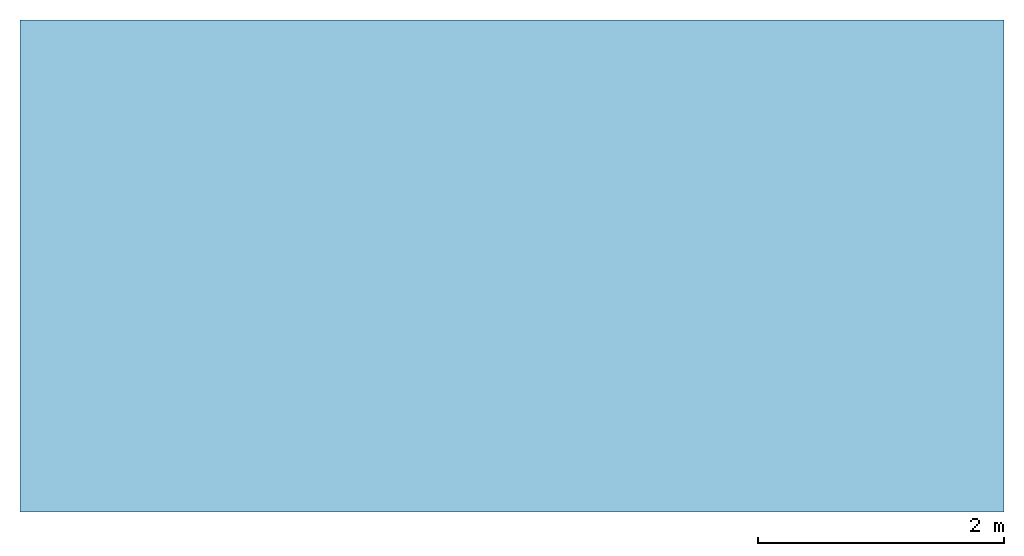
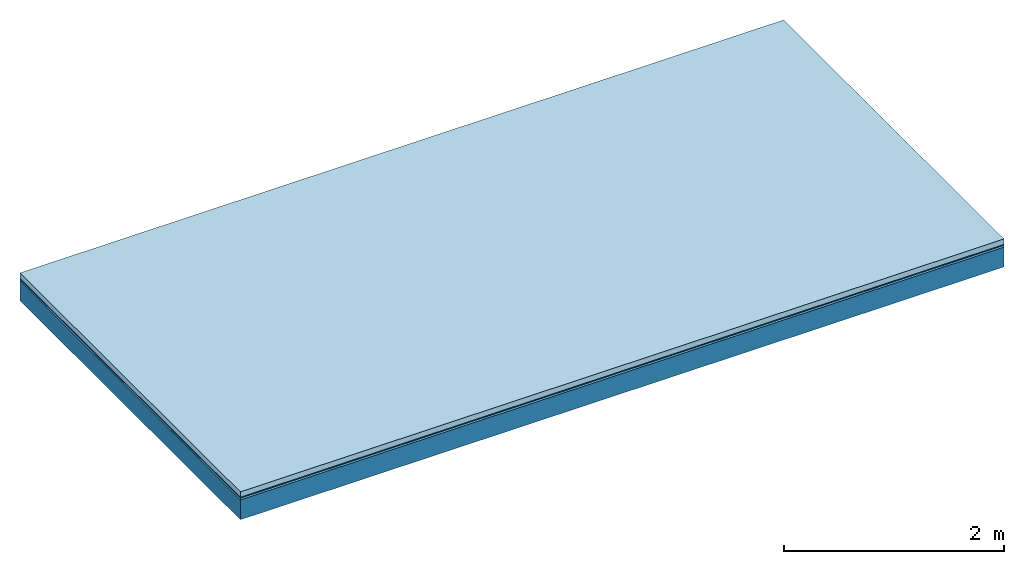
# One storey: 3 plates, 1 member, 1 element without a shape of its own.
"""IFC4 building model written with IfcOpenShell, lengths in metres."""

import ifcopenshell
import ifcopenshell.guid

model = None  # the IFC model being written
_history = None  # IfcOwnerHistory: only IFC2X3 demands one
_inside = {}  # id of a spatial element -> (the spatial element, [elements in it])
_under = {}  # id of a project, library or spatial element -> (it, [spatial elements below it])
_declared = {}  # id of a project -> (the project, [libraries it declares])
_typed = {}  # id of a type object -> (the type object, [elements of that type])
_made_of = {}  # id of a material, layer set ... -> (it, [elements and type objects made of it])


def new_model(schema):
    """Start an empty IFC model of exactly this schema.

    Asked for "IFC4X3", IfcOpenShell would pick the latest addendum, in which some entities
    have other attributes; the version numbers below select the first issue.
    IFC2X3 requires an IfcOwnerHistory on every rooted entity: one is made here for all.
    """
    global model, _history
    if schema == "IFC4X3":
        model = ifcopenshell.file(schema_version=(4, 3, 0, 0))
    else:
        model = ifcopenshell.file(schema=schema)
    _inside.clear()
    _under.clear()
    _declared.clear()
    _typed.clear()
    _made_of.clear()
    _history = None
    if model.schema == "IFC2X3":
        org = make("IfcOrganization", Name="unknown")
        user = make(
            "IfcPersonAndOrganization",
            ThePerson=make("IfcPerson", FamilyName="unknown"),
            TheOrganization=org,
        )
        app = make(
            "IfcApplication",
            ApplicationDeveloper=org,
            Version="unknown",
            ApplicationFullName="unknown",
            ApplicationIdentifier="unknown",
        )
        _history = make(
            "IfcOwnerHistory",
            OwningUser=user,
            OwningApplication=app,
            ChangeAction="ADDED",
            CreationDate=0,
        )
    return model


def make(cls, **values):
    """One entity of the class cls with the attributes given. An attribute that is None is left unset."""
    return model.create_entity(
        cls, **{name: value for name, value in values.items() if value is not None}
    )


def rooted(cls, **values):
    """An entity with a GlobalId (a new one), such as an element, a storey or a relation."""
    return make(cls, GlobalId=ifcopenshell.guid.new(), OwnerHistory=_history, **values)


def si_unit(unit_type, name, prefix=None):
    """IfcSIUnit, for example si_unit("LENGTHUNIT", "METRE", prefix="MILLI")."""
    return make("IfcSIUnit", UnitType=unit_type, Prefix=prefix, Name=name)


def derived_unit(unit_type, elements):
    """IfcDerivedUnit: a product of units, each with its exponent."""
    return make(
        "IfcDerivedUnit",
        Elements=[
            make("IfcDerivedUnitElement", Unit=unit, Exponent=power)
            for unit, power in elements
        ],
        UnitType=unit_type,
    )


def assignment(units):
    """IfcUnitAssignment: the units of a project."""
    return None if units is None else make("IfcUnitAssignment", Units=units)


def point(xyz):
    """IfcCartesianPoint."""
    return None if xyz is None else make("IfcCartesianPoint", Coordinates=xyz)


def direction(xyz):
    """IfcDirection."""
    return None if xyz is None else make("IfcDirection", DirectionRatios=xyz)


def frame(location, z_axis=None, x_axis=None):
    """IfcAxis2Placement3D, a coordinate frame: its origin and axes. An axis left out is left unset."""
    return make(
        "IfcAxis2Placement3D",
        Location=point(location),
        Axis=direction(z_axis),
        RefDirection=direction(x_axis),
    )


def frame_2d(location, x_axis=None):
    """IfcAxis2Placement2D, a coordinate frame in the plane: its origin and x axis."""
    return make(
        "IfcAxis2Placement2D", Location=point(location), RefDirection=direction(x_axis)
    )


def origin():
    """The frame at (0, 0, 0) with its axes left unset."""
    return frame((0.0, 0.0, 0.0))


def origin_with_axes():
    """The frame at (0, 0, 0) with the z axis (0, 0, 1) and the x axis (1, 0, 0) written out."""
    return frame((0.0, 0.0, 0.0), z_axis=(0.0, 0.0, 1.0), x_axis=(1.0, 0.0, 0.0))


def place(relative_to, where):
    """IfcLocalPlacement: puts the frame where relative to a parent placement (None: the world)."""
    return make(
        "IfcLocalPlacement", PlacementRelTo=relative_to, RelativePlacement=where
    )


def context(
    kind, dimensions, precision=None, world=None, true_north=None, identifier=None
):
    """IfcGeometricRepresentationContext, for example the 3D "Model" context."""
    return make(
        "IfcGeometricRepresentationContext",
        ContextIdentifier=identifier,
        ContextType=kind,
        CoordinateSpaceDimension=dimensions,
        Precision=precision,
        WorldCoordinateSystem=world,
        TrueNorth=true_north,
    )


def project(units=None, contexts=None):
    """IfcProject with its units and contexts."""
    return rooted(
        "IfcProject",
        Name="project",
        RepresentationContexts=contexts,
        UnitsInContext=assignment(units),
    )


def spatial(cls, under=None, at=None, **own):
    """A site, building, storey or space (cls), placed at a placement, below another one or the project."""
    s = rooted(cls, ObjectPlacement=at, **own)
    if under is not None:
        _under.setdefault(under.id(), (under, []))[1].append(s)
    return s


def profile(cls, at=None, kind="AREA", **sizes):
    """A parametric profile (cls). Its sizes go by their IFC names, for example OverallWidth=200.0."""
    return make(cls, ProfileType=kind, Position=at, **sizes)


def rectangle(**sizes):
    """IfcRectangleProfileDef."""
    return profile("IfcRectangleProfileDef", **sizes)


def extrude(swept, where, along, depth):
    """IfcExtrudedAreaSolid: the profile swept, set in the frame where, extruded along a direction by depth."""
    return make(
        "IfcExtrudedAreaSolid",
        SweptArea=swept,
        Position=where,
        ExtrudedDirection=direction(along),
        Depth=depth,
    )


def shape(context_of_items, identifier, shape_type, items):
    """IfcShapeRepresentation: the items that make up one representation, for example the "Body"."""
    return make(
        "IfcShapeRepresentation",
        ContextOfItems=context_of_items,
        RepresentationIdentifier=identifier,
        RepresentationType=shape_type,
        Items=items,
    )


def material(Name=None, Category=None):
    """IfcMaterial."""
    return make("IfcMaterial", Name=Name, Category=Category)


def layer(
    of_material, thickness, ventilated=None, Name=None, Category=None, Priority=None
):
    """IfcMaterialLayer: one layer of a wall or slab, of a material (None: an air gap)."""
    return make(
        "IfcMaterialLayer",
        Material=of_material,
        LayerThickness=thickness,
        IsVentilated=ventilated,
        Name=Name,
        Category=Category,
        Priority=Priority,
    )


def layer_set(layers, Name=None):
    """IfcMaterialLayerSet."""
    return make("IfcMaterialLayerSet", MaterialLayers=layers, LayerSetName=Name)


def made_of(thing, what):
    """Note that an element or type object is made of a material, layer set ...; save() writes the relation."""
    if what is not None:
        _made_of.setdefault(what.id(), (what, []))[1].append(thing)
    return thing


def type_object(cls, material=None, **own):
    """A type object (cls), such as IfcWallType, which elements share."""
    return made_of(rooted(cls, **own), material)


def element(
    cls,
    number,
    at=None,
    inside=None,
    cuts=None,
    type_object=None,
    material=None,
    context=None,
    identifier="Body",
    shape_type=None,
    held_by="IfcProductDefinitionShape",
    body=None,
    shapes=None,
    **own,
):
    """One element of the class cls, such as IfcWall. Its Tag is "e" and its number.

    at: its placement. inside: the storey or other place that contains it. cuts: it is an
    opening in that element (IfcRelVoidsElement). A single representation is given by context,
    identifier, shape_type and body (its items); several are given by shapes. held_by: the class
    of the entity that holds the representations. save() writes the other relations.
    """
    e = rooted(cls, Tag="e%d" % number, ObjectPlacement=at, **own)
    if body is not None:
        shapes = [shape(context, identifier, shape_type, body)]
    if shapes is not None:
        e.Representation = make(held_by, Representations=shapes)
    if inside is not None:
        _inside.setdefault(inside.id(), (inside, []))[1].append(e)
    if cuts is not None:
        rooted(
            "IfcRelVoidsElement", RelatingBuildingElement=cuts, RelatedOpeningElement=e
        )
    if type_object is not None:
        _typed.setdefault(type_object.id(), (type_object, []))[1].append(e)
    return made_of(e, material)


def aggregate(whole, parts):
    """IfcRelAggregates: a whole, such as a stair, and the parts it consists of."""
    return rooted("IfcRelAggregates", RelatingObject=whole, RelatedObjects=parts)


def save(model, path):
    """Write the relations noted so far, then the file.

    IfcRelAggregates (storeys below a building ...), IfcRelContainedInSpatialStructure (elements
    in a storey), IfcRelDefinesByType, IfcRelAssociatesMaterial and IfcRelDeclares: one each for
    every whole, place, type object, material and project.
    """
    for whole, parts in _under.values():
        aggregate(whole, parts)
    for where, things in _inside.values():
        rooted(
            "IfcRelContainedInSpatialStructure",
            RelatedElements=things,
            RelatingStructure=where,
        )
    for kind, things in _typed.values():
        rooted("IfcRelDefinesByType", RelatedObjects=things, RelatingType=kind)
    for what, things in _made_of.values():
        rooted("IfcRelAssociatesMaterial", RelatedObjects=things, RelatingMaterial=what)
    for by, libraries in _declared.values():
        rooted("IfcRelDeclares", RelatingContext=by, RelatedDefinitions=libraries)
    model.write(path)


model = new_model("IFC4")

# Units and contexts
plan_context = context("Plan", 3, precision=1e-05, world=origin(), true_north=direction((0.0, 1.0)))
model_context = context("Model", 3, precision=1e-05, world=origin(), true_north=direction((0.0, 1.0)))
ifc_project = project(units=[si_unit("LENGTHUNIT", "METRE"), derived_unit("SOUNDPRESSUREUNIT", [(si_unit("PRESSUREUNIT", "PASCAL", prefix="MICRO"), 0)]), si_unit("ENERGYUNIT", "JOULE", prefix="MEGA"), si_unit("MASSUNIT", "GRAM", prefix="KILO"), derived_unit("THERMALTRANSMITTANCEUNIT", [(si_unit("POWERUNIT", "WATT"), 1), (si_unit("AREAUNIT", "SQUARE_METRE"), -1), (si_unit("THERMODYNAMICTEMPERATUREUNIT", "KELVIN"), -1)]), derived_unit("AREADENSITYUNIT", [(si_unit("MASSUNIT", "GRAM", prefix="KILO"), 1), (si_unit("AREAUNIT", "SQUARE_METRE"), -1)]), derived_unit("USERDEFINED", [(si_unit("ENERGYUNIT", "JOULE", prefix="MEGA"), 1), (si_unit("AREAUNIT", "SQUARE_METRE"), -1)])], contexts=[plan_context, model_context])

# Site, building, storey
site = spatial("IfcSite", under=ifc_project)
building_placement = place(None, origin())
building = spatial("IfcBuilding", under=site, at=building_placement)
storey_placement = place(building_placement, origin())
storey = spatial("IfcBuildingStorey", under=building, at=storey_placement)

# Slab, member, plates
ifc_material_1 = material(Name="clay", Category="02.004")
ifc_layer_1 = layer(ifc_material_1, 0.06, Name="Use and protection layer 2")
ifc_material_2 = material(Name="Protective layer", Category="09.007")
ifc_layer_2 = layer(ifc_material_2, 0.01, Name="Use and protection layer 1")
ifc_material_3 = material(Name="Bituminous", Category="09.003")
ifc_layer_3 = layer(ifc_material_3, 0.02, Name="Seal")
ifc_material_4 = material(Name="no composite action")
ifc_layer_4 = layer(ifc_material_4, 0.0, Name="Bond")
ifc_layer_5 = layer(None, 0.22, Name="Support")
ifc_layer_set = layer_set([ifc_layer_1, ifc_layer_2, ifc_layer_3, ifc_layer_4, ifc_layer_5])
slab_type = type_object("IfcSlabType", Name="F0036", PredefinedType="NOTDEFINED", material=ifc_layer_set)
slab_placement = place(None, frame((0.0, 0.0, 0.0), z_axis=(0.0, 0.0, -1.0), x_axis=(1.0, 0.0, 0.0)))
slab = element("IfcSlab", 1, at=slab_placement, inside=storey, type_object=slab_type, material=ifc_layer_set, Name="Slab #1")
ifc_material_5 = material(Name="Solid timber panel")
member_placement = place(slab_placement, origin())
member = element("IfcMember", 2, at=member_placement, material=ifc_material_5, Name="Support", context=plan_context, shape_type="SweptSolid", body=[
    extrude(rectangle(XDim=1.0, YDim=0.22, at=frame_2d((0.5, 0.11), x_axis=(1.0, 0.0))), frame((0.0, 4.0, 0.09), z_axis=(0.0, -1.0, 0.0), x_axis=(1.0, 0.0, 0.0)), (0.0, 0.0, 1.0), 4.0),
    extrude(rectangle(XDim=1.0, YDim=0.22, at=frame_2d((0.5, 0.11), x_axis=(1.0, 0.0))), frame((1.0, 4.0, 0.09), z_axis=(0.0, -1.0, 0.0), x_axis=(1.0, 0.0, 0.0)), (0.0, 0.0, 1.0), 4.0),
    extrude(rectangle(XDim=1.0, YDim=0.22, at=frame_2d((0.5, 0.11), x_axis=(1.0, 0.0))), frame((2.0, 4.0, 0.09), z_axis=(0.0, -1.0, 0.0), x_axis=(1.0, 0.0, 0.0)), (0.0, 0.0, 1.0), 4.0),
    extrude(rectangle(XDim=1.0, YDim=0.22, at=frame_2d((0.5, 0.11), x_axis=(1.0, 0.0))), frame((3.0, 4.0, 0.09), z_axis=(0.0, -1.0, 0.0), x_axis=(1.0, 0.0, 0.0)), (0.0, 0.0, 1.0), 4.0),
    extrude(rectangle(XDim=1.0, YDim=0.22, at=frame_2d((0.5, 0.11), x_axis=(1.0, 0.0))), frame((4.0, 4.0, 0.09), z_axis=(0.0, -1.0, 0.0), x_axis=(1.0, 0.0, 0.0)), (0.0, 0.0, 1.0), 4.0),
    extrude(rectangle(XDim=1.0, YDim=0.22, at=frame_2d((0.5, 0.11), x_axis=(1.0, 0.0))), frame((5.0, 4.0, 0.09), z_axis=(0.0, -1.0, 0.0), x_axis=(1.0, 0.0, 0.0)), (0.0, 0.0, 1.0), 4.0),
    extrude(rectangle(XDim=1.0, YDim=0.22, at=frame_2d((0.5, 0.11), x_axis=(1.0, 0.0))), frame((6.0, 4.0, 0.09), z_axis=(0.0, -1.0, 0.0), x_axis=(1.0, 0.0, 0.0)), (0.0, 0.0, 1.0), 4.0),
    extrude(rectangle(XDim=1.0, YDim=0.22, at=frame_2d((0.5, 0.11), x_axis=(1.0, 0.0))), frame((7.0, 4.0, 0.09), z_axis=(0.0, -1.0, 0.0), x_axis=(1.0, 0.0, 0.0)), (0.0, 0.0, 1.0), 4.0),
])
plate_1_placement = place(slab_placement, origin())
plate_1 = element("IfcPlate", 3, at=plate_1_placement, material=ifc_material_1, Name="Use and protection layer 2", context=plan_context, shape_type="SweptSolid", body=[
    extrude(rectangle(XDim=8.0, YDim=4.0, at=frame_2d((4.0, 2.0), x_axis=(1.0, 0.0))), origin_with_axes(), (0.0, 0.0, 1.0), 0.06),
])
plate_2_placement = place(slab_placement, origin())
plate_2 = element("IfcPlate", 4, at=plate_2_placement, material=ifc_material_2, Name="Use and protection layer 1", context=plan_context, shape_type="SweptSolid", body=[
    extrude(rectangle(XDim=8.0, YDim=4.0, at=frame_2d((4.0, 2.0), x_axis=(1.0, 0.0))), frame((0.0, 0.0, 0.06), z_axis=(0.0, 0.0, 1.0), x_axis=(1.0, 0.0, 0.0)), (0.0, 0.0, 1.0), 0.01),
])
plate_3_placement = place(slab_placement, origin())
plate_3 = element("IfcPlate", 5, at=plate_3_placement, material=ifc_material_3, Name="Seal", context=plan_context, shape_type="SweptSolid", body=[
    extrude(rectangle(XDim=8.0, YDim=4.0, at=frame_2d((4.0, 2.0), x_axis=(1.0, 0.0))), frame((0.0, 0.0, 0.07), z_axis=(0.0, 0.0, 1.0), x_axis=(1.0, 0.0, 0.0)), (0.0, 0.0, 1.0), 0.02),
])
aggregate(slab, [plate_1, plate_2, plate_3, member])

save(model, "model.ifc")
